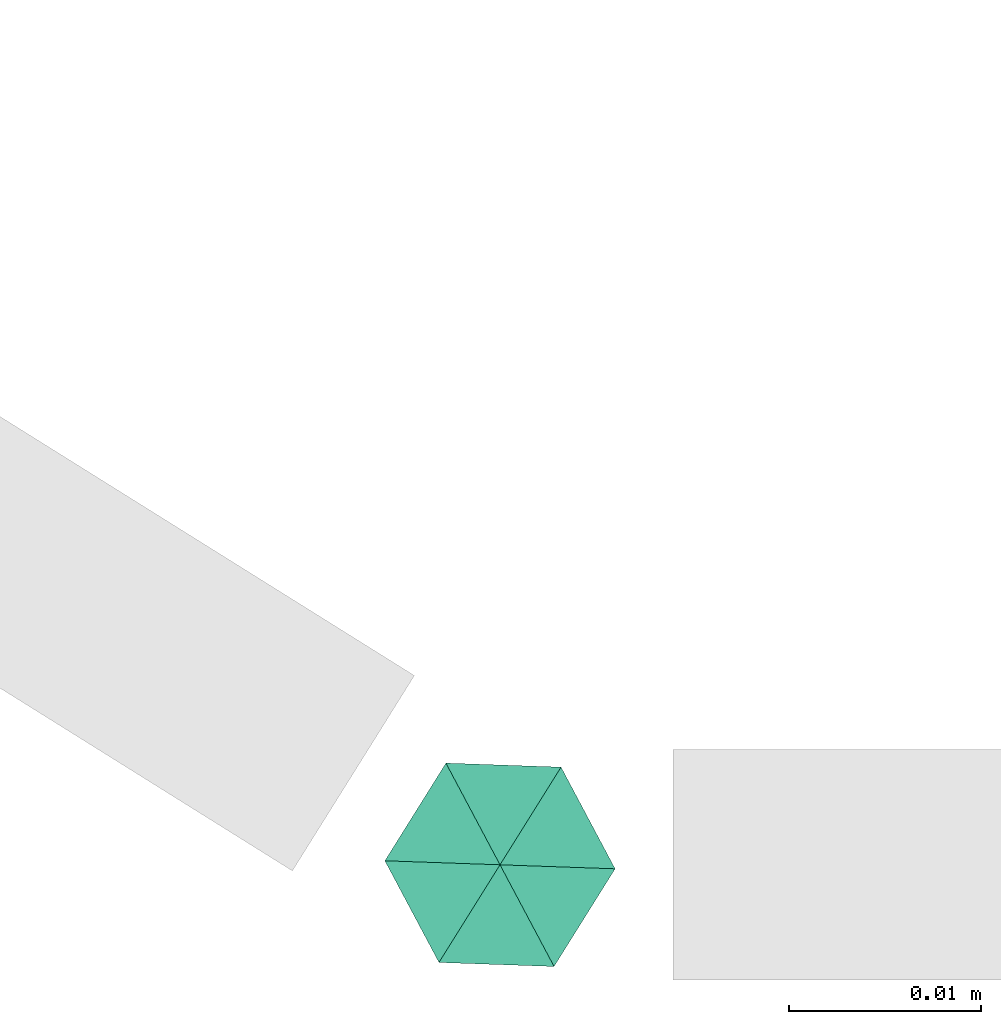
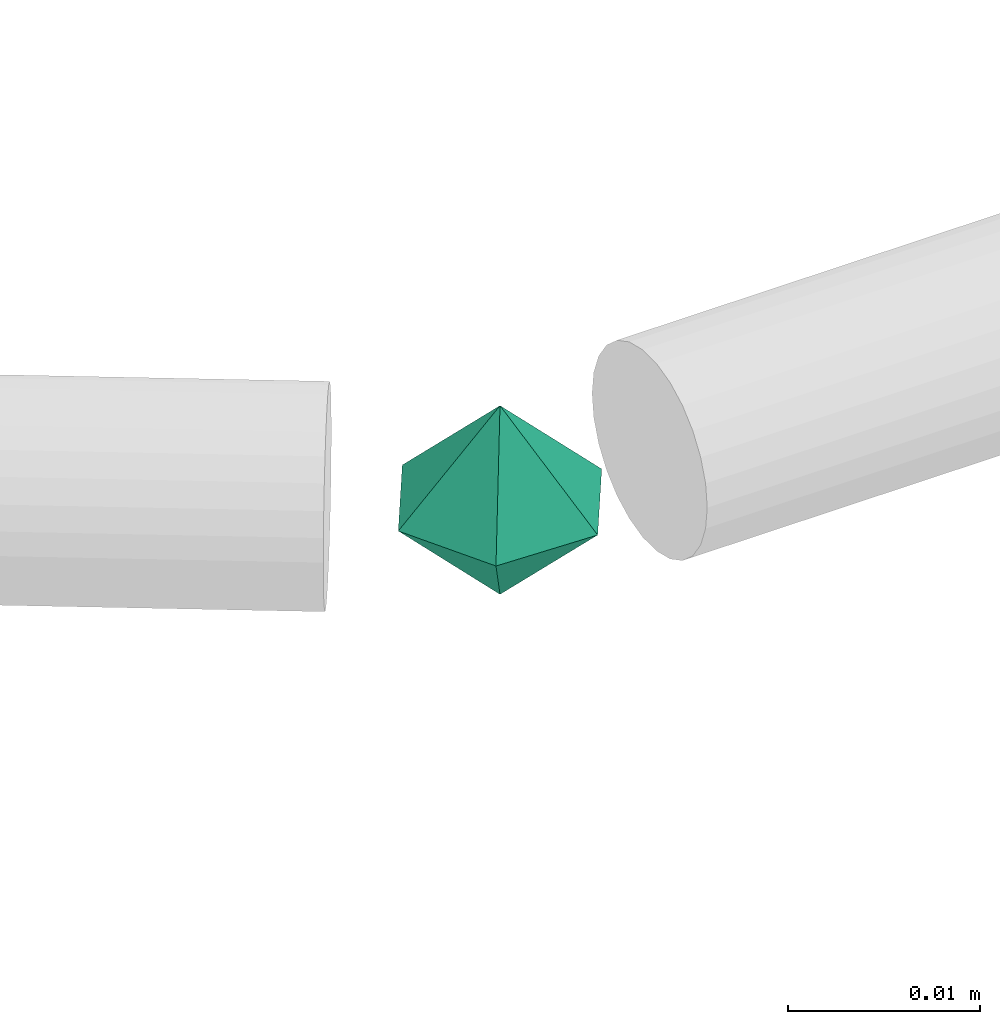
# One storey, part 65 of 65: 1 flow fitting.
"""IFC2X3 building model written with IfcOpenShell, lengths in millimetres."""

import ifcopenshell
import ifcopenshell.guid

model = None  # the IFC model being written
_history = None  # IfcOwnerHistory: only IFC2X3 demands one
_inside = {}  # id of a spatial element -> (the spatial element, [elements in it])
_under = {}  # id of a project, library or spatial element -> (it, [spatial elements below it])
_declared = {}  # id of a project -> (the project, [libraries it declares])
_typed = {}  # id of a type object -> (the type object, [elements of that type])
_made_of = {}  # id of a material, layer set ... -> (it, [elements and type objects made of it])


def new_model(schema):
    """Start an empty IFC model of exactly this schema.

    Asked for "IFC4X3", IfcOpenShell would pick the latest addendum, in which some entities
    have other attributes; the version numbers below select the first issue.
    IFC2X3 requires an IfcOwnerHistory on every rooted entity: one is made here for all.
    """
    global model, _history
    if schema == "IFC4X3":
        model = ifcopenshell.file(schema_version=(4, 3, 0, 0))
    else:
        model = ifcopenshell.file(schema=schema)
    _inside.clear()
    _under.clear()
    _declared.clear()
    _typed.clear()
    _made_of.clear()
    _history = None
    if model.schema == "IFC2X3":
        org = make("IfcOrganization", Name="unknown")
        user = make(
            "IfcPersonAndOrganization",
            ThePerson=make("IfcPerson", FamilyName="unknown"),
            TheOrganization=org,
        )
        app = make(
            "IfcApplication",
            ApplicationDeveloper=org,
            Version="unknown",
            ApplicationFullName="unknown",
            ApplicationIdentifier="unknown",
        )
        _history = make(
            "IfcOwnerHistory",
            OwningUser=user,
            OwningApplication=app,
            ChangeAction="ADDED",
            CreationDate=0,
        )
    return model


def make(cls, **values):
    """One entity of the class cls with the attributes given. An attribute that is None is left unset."""
    return model.create_entity(
        cls, **{name: value for name, value in values.items() if value is not None}
    )


def entity(cls, *values):
    """Any entity or typed value of the class cls, its attributes in the order of the schema. None: left unset."""
    e = model.create_entity(cls)
    for i, value in enumerate(values):
        if value is not None:
            e[i] = value
    return e


def rooted(cls, **values):
    """An entity with a GlobalId (a new one), such as an element, a storey or a relation."""
    return make(cls, GlobalId=ifcopenshell.guid.new(), OwnerHistory=_history, **values)


def si_unit(unit_type, name, prefix=None):
    """IfcSIUnit, for example si_unit("LENGTHUNIT", "METRE", prefix="MILLI")."""
    return make("IfcSIUnit", UnitType=unit_type, Prefix=prefix, Name=name)


def converted_unit(unit_type, name, factor, base, dimensions=None, offset=None):
    """IfcConversionBasedUnit, such as the inch: factor (a typed value) times the base unit."""
    return make(
        "IfcConversionBasedUnit"
        if offset is None
        else "IfcConversionBasedUnitWithOffset",
        ConversionOffset=offset,
        Dimensions=None
        if dimensions is None
        else entity("IfcDimensionalExponents", *dimensions),
        UnitType=unit_type,
        Name=name,
        ConversionFactor=make(
            "IfcMeasureWithUnit", ValueComponent=factor, UnitComponent=base
        ),
    )


def derived_unit(unit_type, elements):
    """IfcDerivedUnit: a product of units, each with its exponent."""
    return make(
        "IfcDerivedUnit",
        Elements=[
            make("IfcDerivedUnitElement", Unit=unit, Exponent=power)
            for unit, power in elements
        ],
        UnitType=unit_type,
    )


def assignment(units):
    """IfcUnitAssignment: the units of a project."""
    return None if units is None else make("IfcUnitAssignment", Units=units)


def point(xyz):
    """IfcCartesianPoint."""
    return None if xyz is None else make("IfcCartesianPoint", Coordinates=xyz)


def direction(xyz):
    """IfcDirection."""
    return None if xyz is None else make("IfcDirection", DirectionRatios=xyz)


def frame(location, z_axis=None, x_axis=None):
    """IfcAxis2Placement3D, a coordinate frame: its origin and axes. An axis left out is left unset."""
    return make(
        "IfcAxis2Placement3D",
        Location=point(location),
        Axis=direction(z_axis),
        RefDirection=direction(x_axis),
    )


def origin():
    """The frame at (0, 0, 0) with its axes left unset."""
    return frame((0.0, 0.0, 0.0))


def place(relative_to, where):
    """IfcLocalPlacement: puts the frame where relative to a parent placement (None: the world)."""
    return make(
        "IfcLocalPlacement", PlacementRelTo=relative_to, RelativePlacement=where
    )


def context(
    kind, dimensions, precision=None, world=None, true_north=None, identifier=None
):
    """IfcGeometricRepresentationContext, for example the 3D "Model" context."""
    return make(
        "IfcGeometricRepresentationContext",
        ContextIdentifier=identifier,
        ContextType=kind,
        CoordinateSpaceDimension=dimensions,
        Precision=precision,
        WorldCoordinateSystem=world,
        TrueNorth=true_north,
    )


def subcontext(parent, identifier, kind, view, scale=None):
    """IfcGeometricRepresentationSubContext, for example "Body" below "Model"."""
    return make(
        "IfcGeometricRepresentationSubContext",
        ContextIdentifier=identifier,
        ContextType=kind,
        ParentContext=parent,
        TargetScale=scale,
        TargetView=view,
    )


def project(units=None, contexts=None):
    """IfcProject with its units and contexts."""
    return rooted(
        "IfcProject",
        Name="project",
        RepresentationContexts=contexts,
        UnitsInContext=assignment(units),
    )


def spatial(cls, under=None, at=None, **own):
    """A site, building, storey or space (cls), placed at a placement, below another one or the project."""
    s = rooted(cls, ObjectPlacement=at, **own)
    if under is not None:
        _under.setdefault(under.id(), (under, []))[1].append(s)
    return s


def faces_of(points, faces, orient=None, outer=None):
    """IfcFace entities. A face is a list of loops; a loop is a list of indices into points, from 0.

    orient and outer hold one flag for each loop. By default every Orientation is true, the
    first loop of a face is its IfcFaceOuterBound and the others are IfcFaceBound.
    """
    made = []
    for i, loops in enumerate(faces):
        bounds = []
        for j, loop in enumerate(loops):
            is_outer = j == 0 if outer is None else outer[i][j]
            bounds.append(
                make(
                    "IfcFaceOuterBound" if is_outer else "IfcFaceBound",
                    Bound=make("IfcPolyLoop", Polygon=[points[k] for k in loop]),
                    Orientation=True if orient is None else orient[i][j],
                )
            )
        made.append(make("IfcFace", Bounds=bounds))
    return made


def faceted_brep(points, faces, orient=None, outer=None, voids=None):
    """IfcFacetedBrep: a solid bounded by flat faces; with voids (closed shells), ...WithVoids."""
    shared = [point(p) for p in points]
    hull = make("IfcClosedShell", CfsFaces=faces_of(shared, faces, orient, outer))
    if voids is None:
        return make("IfcFacetedBrep", Outer=hull)
    return make(
        "IfcFacetedBrepWithVoids",
        Outer=hull,
        Voids=[
            make(cls, CfsFaces=faces_of(shared, fs, o, b)) for cls, fs, o, b in voids
        ],
    )


def shape(context_of_items, identifier, shape_type, items):
    """IfcShapeRepresentation: the items that make up one representation, for example the "Body"."""
    return make(
        "IfcShapeRepresentation",
        ContextOfItems=context_of_items,
        RepresentationIdentifier=identifier,
        RepresentationType=shape_type,
        Items=items,
    )


def source(mapping_origin, context_of_items, identifier, shape_type, items):
    """IfcRepresentationMap: a shape defined once, which mapped items show again and again."""
    return make(
        "IfcRepresentationMap",
        MappingOrigin=mapping_origin,
        MappedRepresentation=shape(context_of_items, identifier, shape_type, items),
    )


def transform(
    local_origin,
    x_axis=None,
    y_axis=None,
    z_axis=None,
    scale=None,
    scale2=None,
    scale3=None,
    uniform=True,
):
    """IfcCartesianTransformationOperator3D, or its non-uniform kind. x_axis, y_axis, z_axis: its Axis1, 2, 3."""
    if uniform:
        return make(
            "IfcCartesianTransformationOperator3D",
            Axis1=direction(x_axis),
            Axis2=direction(y_axis),
            LocalOrigin=point(local_origin),
            Scale=scale,
            Axis3=direction(z_axis),
        )
    return make(
        "IfcCartesianTransformationOperator3DnonUniform",
        Axis1=direction(x_axis),
        Axis2=direction(y_axis),
        LocalOrigin=point(local_origin),
        Scale=scale,
        Axis3=direction(z_axis),
        Scale2=scale2,
        Scale3=scale3,
    )


def mapped(mapping_source, mapping_target):
    """IfcMappedItem: shows the shape of a source again, moved by a transform."""
    return make(
        "IfcMappedItem", MappingSource=mapping_source, MappingTarget=mapping_target
    )


def material(Name=None, Category=None):
    """IfcMaterial."""
    return make("IfcMaterial", Name=Name, Category=Category)


def material_list(materials):
    """IfcMaterialList."""
    return make("IfcMaterialList", Materials=materials)


def made_of(thing, what):
    """Note that an element or type object is made of a material, layer set ...; save() writes the relation."""
    if what is not None:
        _made_of.setdefault(what.id(), (what, []))[1].append(thing)
    return thing


def type_object(cls, material=None, **own):
    """A type object (cls), such as IfcWallType, which elements share."""
    return made_of(rooted(cls, **own), material)


def type_shapes(of_type, sources):
    """Give a type object the sources (RepresentationMaps) that its elements show as mapped items."""
    of_type.RepresentationMaps = sources


def element(
    cls,
    number,
    at=None,
    inside=None,
    cuts=None,
    type_object=None,
    material=None,
    context=None,
    identifier="Body",
    shape_type=None,
    held_by="IfcProductDefinitionShape",
    body=None,
    shapes=None,
    **own,
):
    """One element of the class cls, such as IfcWall. Its Tag is "e" and its number.

    at: its placement. inside: the storey or other place that contains it. cuts: it is an
    opening in that element (IfcRelVoidsElement). A single representation is given by context,
    identifier, shape_type and body (its items); several are given by shapes. held_by: the class
    of the entity that holds the representations. save() writes the other relations.
    """
    e = rooted(cls, Tag="e%d" % number, ObjectPlacement=at, **own)
    if body is not None:
        shapes = [shape(context, identifier, shape_type, body)]
    if shapes is not None:
        e.Representation = make(held_by, Representations=shapes)
    if inside is not None:
        _inside.setdefault(inside.id(), (inside, []))[1].append(e)
    if cuts is not None:
        rooted(
            "IfcRelVoidsElement", RelatingBuildingElement=cuts, RelatedOpeningElement=e
        )
    if type_object is not None:
        _typed.setdefault(type_object.id(), (type_object, []))[1].append(e)
    return made_of(e, material)


def aggregate(whole, parts):
    """IfcRelAggregates: a whole, such as a stair, and the parts it consists of."""
    return rooted("IfcRelAggregates", RelatingObject=whole, RelatedObjects=parts)


def save(model, path):
    """Write the relations noted so far, then the file.

    IfcRelAggregates (storeys below a building ...), IfcRelContainedInSpatialStructure (elements
    in a storey), IfcRelDefinesByType, IfcRelAssociatesMaterial and IfcRelDeclares: one each for
    every whole, place, type object, material and project.
    """
    for whole, parts in _under.values():
        aggregate(whole, parts)
    for where, things in _inside.values():
        rooted(
            "IfcRelContainedInSpatialStructure",
            RelatedElements=things,
            RelatingStructure=where,
        )
    for kind, things in _typed.values():
        rooted("IfcRelDefinesByType", RelatedObjects=things, RelatingType=kind)
    for what, things in _made_of.values():
        rooted("IfcRelAssociatesMaterial", RelatedObjects=things, RelatingMaterial=what)
    for by, libraries in _declared.values():
        rooted("IfcRelDeclares", RelatingContext=by, RelatedDefinitions=libraries)
    model.write(path)


model = new_model("IFC2X3")

# Units and contexts
model_context = context("Model", 3, precision=0.01, world=origin(), true_north=direction((6.12303176911189e-17, 1.0)))
body_context = subcontext(model_context, "Body", "Model", "MODEL_VIEW")
ifc_project = project(units=[si_unit("LENGTHUNIT", "METRE", prefix="MILLI"), si_unit("AREAUNIT", "SQUARE_METRE"), si_unit("VOLUMEUNIT", "CUBIC_METRE"), converted_unit("PLANEANGLEUNIT", "DEGREE", entity("IfcRatioMeasure", 0.0174532925199433), si_unit("PLANEANGLEUNIT", "RADIAN"), dimensions=[0, 0, 0, 0, 0, 0, 0]), si_unit("MASSUNIT", "GRAM", prefix="KILO"), derived_unit("MASSDENSITYUNIT", [(si_unit("MASSUNIT", "GRAM", prefix="KILO"), 1), (si_unit("LENGTHUNIT", "METRE"), -3)]), derived_unit("MOMENTOFINERTIAUNIT", [(si_unit("LENGTHUNIT", "METRE"), 4)]), si_unit("TIMEUNIT", "SECOND"), si_unit("FREQUENCYUNIT", "HERTZ"), si_unit("THERMODYNAMICTEMPERATUREUNIT", "DEGREE_CELSIUS"), derived_unit("THERMALTRANSMITTANCEUNIT", [(si_unit("MASSUNIT", "GRAM", prefix="KILO"), 1), (si_unit("THERMODYNAMICTEMPERATUREUNIT", "KELVIN"), -1), (si_unit("TIMEUNIT", "SECOND"), -3)]), derived_unit("VOLUMETRICFLOWRATEUNIT", [(si_unit("LENGTHUNIT", "METRE"), 3), (si_unit("TIMEUNIT", "SECOND"), -1)]), derived_unit("MASSFLOWRATEUNIT", [(si_unit("MASSUNIT", "GRAM", prefix="KILO"), 1), (si_unit("TIMEUNIT", "SECOND"), -1)]), derived_unit("ROTATIONALFREQUENCYUNIT", [(si_unit("TIMEUNIT", "SECOND"), -1)]), si_unit("ELECTRICCURRENTUNIT", "AMPERE"), si_unit("ELECTRICVOLTAGEUNIT", "VOLT"), si_unit("POWERUNIT", "WATT"), si_unit("FORCEUNIT", "NEWTON", prefix="KILO"), si_unit("ILLUMINANCEUNIT", "LUX"), si_unit("LUMINOUSFLUXUNIT", "LUMEN"), si_unit("LUMINOUSINTENSITYUNIT", "CANDELA"), derived_unit("USERDEFINED", [(si_unit("MASSUNIT", "GRAM", prefix="KILO"), -1), (si_unit("LENGTHUNIT", "METRE"), -2), (si_unit("TIMEUNIT", "SECOND"), 3), (si_unit("LUMINOUSFLUXUNIT", "LUMEN"), 1)]), derived_unit("LINEARVELOCITYUNIT", [(si_unit("LENGTHUNIT", "METRE"), 1), (si_unit("TIMEUNIT", "SECOND"), -1)]), si_unit("PRESSUREUNIT", "PASCAL"), derived_unit("USERDEFINED", [(si_unit("LENGTHUNIT", "METRE"), -2), (si_unit("MASSUNIT", "GRAM", prefix="KILO"), 1), (si_unit("TIMEUNIT", "SECOND"), -2)]), derived_unit("LINEARFORCEUNIT", [(si_unit("MASSUNIT", "GRAM", prefix="KILO"), 1), (si_unit("LENGTHUNIT", "METRE"), 1), (si_unit("TIMEUNIT", "SECOND"), -2), (si_unit("LENGTHUNIT", "METRE"), -1)]), derived_unit("PLANARFORCEUNIT", [(si_unit("MASSUNIT", "GRAM", prefix="KILO"), 1), (si_unit("LENGTHUNIT", "METRE"), 1), (si_unit("TIMEUNIT", "SECOND"), -2), (si_unit("LENGTHUNIT", "METRE"), -2)])], contexts=[model_context])

# Site, building, storey
site_placement = place(None, frame((0.0, -0.00077364408347762, 0.0)))
site = spatial("IfcSite", under=ifc_project, at=site_placement, CompositionType="ELEMENT")
building_placement = place(site_placement, origin())
building = spatial("IfcBuilding", under=site, at=building_placement, CompositionType="ELEMENT")
storey_placement = place(building_placement, frame((0.0, 0.0, 19800.0)))
storey = spatial("IfcBuildingStorey", under=building, at=storey_placement, CompositionType="ELEMENT", Elevation=19800.0)

# Flow fitting
ifc_material_1 = material()
ifc_material_2 = material()
ifc_material_list = material_list([ifc_material_2, ifc_material_1])
pipe_fitting_type = type_object("IfcPipeFittingType", PredefinedType="NOTDEFINED", material=ifc_material_list)
shared_shape = source(origin(), body_context, "Body", "Brep", [
    faceted_brep([(5.19615242271291, 3.0, 0.0), (1.81736279215797e-07, 1.95255435220254e-07, -6.0), (0.0, 6.0, 0.0), (5.19615242271289, -3.0, 0.0), (0.0, -6.0, 0.0), (-5.19615242270038, 3.0, 0.0), (-5.19615242270037, -3.0, 0.0), (-7.73803144365858e-08, 6.63990943561288e-08, 6.0)], [[[0, 1, 2]], [[1, 0, 3]], [[1, 3, 4]], [[5, 1, 6]], [[1, 4, 6]], [[2, 1, 5]], [[5, 7, 2]], [[7, 5, 6]], [[7, 6, 4]], [[0, 7, 3]], [[7, 4, 3]], [[2, 7, 0]]]),
])
type_shapes(pipe_fitting_type, [shared_shape])
flow_fitting_placement = place(storey_placement, frame((20450.8637699032, 350.0, 3050.0), z_axis=(0.0, 0.0, 1.0), x_axis=(0.848048096156425, -0.529919264233207, 0.0)))
element("IfcFlowFitting", 1, at=flow_fitting_placement, inside=storey, type_object=pipe_fitting_type, material=ifc_material_1, context=body_context, shape_type="MappedRepresentation", body=[
    mapped(shared_shape, transform((0.0, 0.0, 0.0), scale=1.0)),
])

save(model, "model.ifc")
